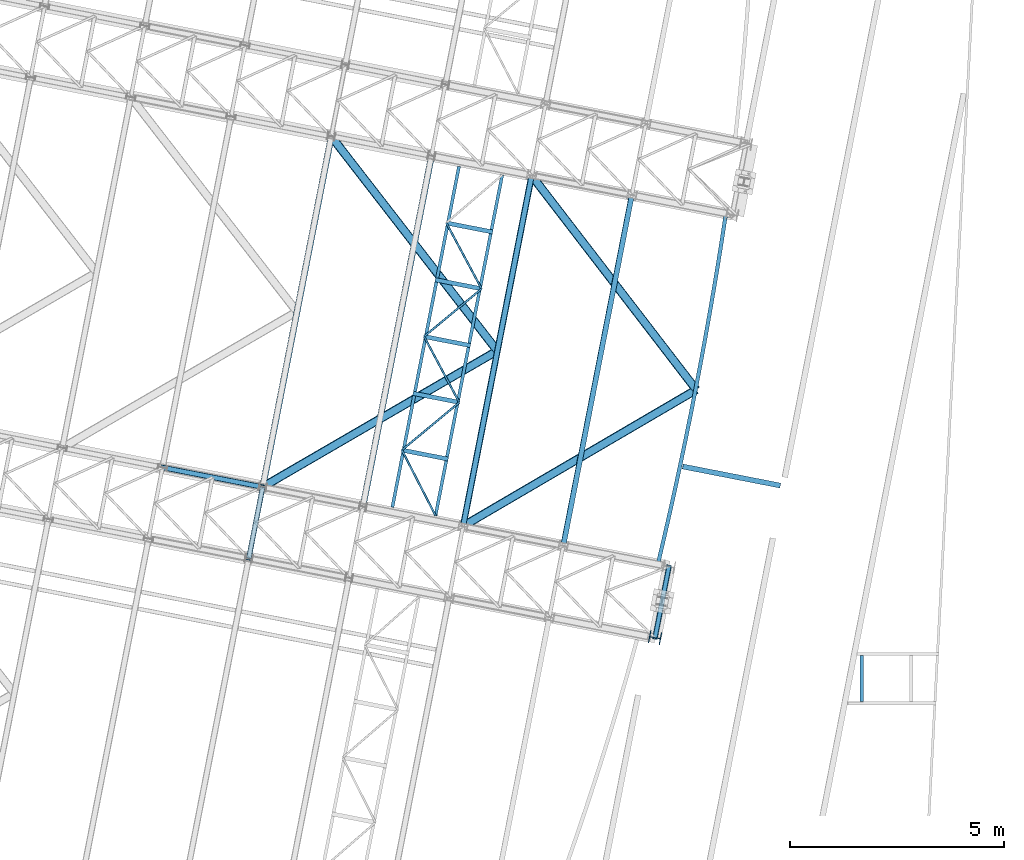
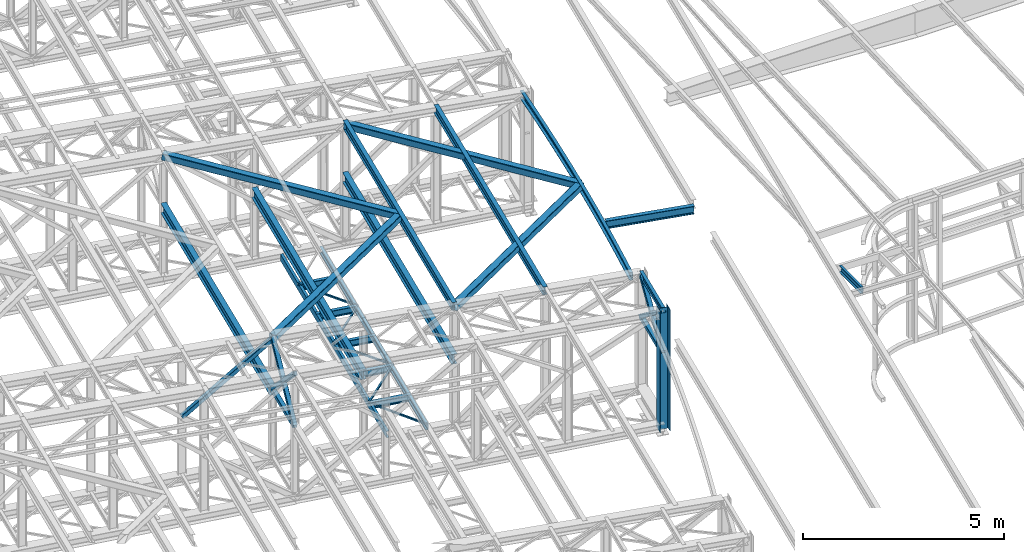
# One storey, part 62 of 215: 28 beams, 5 members, 33 elements without a shape of their own.
"""IFC2X3 building model written with IfcOpenShell, lengths in millimetres."""

from ifc_helpers import new_model, entity, si_unit, frame, origin_with_axes, origin_2d_with_axis, place, context, subcontext, project, spatial, hollow_rectangle, i_section, u_section, extrude, material, type_object, element, aggregate, save


model = new_model("IFC2X3")

# Units and contexts
model_context = context("Model", 3, precision=1e-05, world=origin_with_axes())
body_context = subcontext(model_context, "Body", "Model", "MODEL_VIEW")
ifc_project = project(units=[si_unit("LENGTHUNIT", "METRE", prefix="MILLI"), si_unit("AREAUNIT", "SQUARE_METRE"), si_unit("VOLUMEUNIT", "CUBIC_METRE"), si_unit("MASSUNIT", "GRAM", prefix="KILO"), si_unit("TIMEUNIT", "SECOND"), si_unit("PLANEANGLEUNIT", "RADIAN"), si_unit("SOLIDANGLEUNIT", "STERADIAN"), si_unit("THERMODYNAMICTEMPERATUREUNIT", "DEGREE_CELSIUS"), si_unit("LUMINOUSINTENSITYUNIT", "LUMEN")], contexts=[model_context])

# Site, building, storey
site_placement = place(None, origin_with_axes())
site = spatial("IfcSite", under=ifc_project, at=site_placement, CompositionType="ELEMENT")
building_placement = place(site_placement, origin_with_axes())
building = spatial("IfcBuilding", under=site, at=building_placement, Name="Undefined", CompositionType="ELEMENT")
storey_placement = place(building_placement, origin_with_axes())
storey = spatial("IfcBuildingStorey", under=building, at=storey_placement, Name="Undefined", CompositionType="ELEMENT", Elevation=0.0)

# Assembly, beam
assembly_1_placement = place(storey_placement, origin_with_axes())
assembly_1 = element("IfcElementAssembly", 1, at=assembly_1_placement, inside=storey, Name="Steel Assembly", AssemblyPlace="NOTDEFINED", PredefinedType="RIGID_FRAME")
ifc_material_1 = material(Name="STEEL/S275JR")
beam_type_1 = type_object("IfcBeamType", Name="IPE240", PredefinedType="NOTDEFINED")
beam_1_placement = place(assembly_1_placement, frame((95611.7119283213, 26204.0396014727, 11987.445961115), z_axis=(0.0304080349965938, -0.00594450399933318, 0.999519891888024), x_axis=(-0.980951221876683, 0.191767344975893, 0.0309836359961049)))
beam_1 = element("IfcBeam", 2, at=beam_1_placement, type_object=beam_type_1, material=ifc_material_1, Name="TRAVERSE", ObjectType="IPE240", context=body_context, shape_type="SweptSolid", body=[
    extrude(i_section(OverallWidth=120.0, OverallDepth=240.0, WebThickness=6.199999809, FlangeThickness=9.800000191, FilletRadius=15.0, at=origin_2d_with_axis()), frame((2325.21493417492, -8.17751819121875e-15, 1.81898940354586e-12), z_axis=(-1.0, 0.0, 0.0), x_axis=(-6.93889390390723e-18, -1.0, -3.46944695195361e-18)), (0.0, 0.0, 1.0), 2325.2),
])
aggregate(assembly_1, [beam_1])

assembly_2_placement = place(storey_placement, origin_with_axes())
assembly_2 = element("IfcElementAssembly", 3, at=assembly_2_placement, inside=storey, Name="Steel Assembly", AssemblyPlace="NOTDEFINED", PredefinedType="RIGID_FRAME")
beam_2_placement = place(assembly_2_placement, frame((90534.3986984975, 24794.5320727854, 12133.5283988097), z_axis=(0.0304080349965938, -0.00594450399933318, 0.999519891888024), x_axis=(0.191859470081235, 0.981422408415534, 0.0)))
beam_2 = element("IfcBeam", 4, at=beam_2_placement, type_object=beam_type_1, material=ifc_material_1, ObjectType="IPE240", context=body_context, shape_type="SweptSolid", body=[
    extrude(i_section(OverallWidth=120.0, OverallDepth=240.0, WebThickness=6.199999809, FlangeThickness=9.800000191, FilletRadius=15.0, at=origin_2d_with_axis()), frame((8361.40106173832, 0.0, -1.81898940354586e-12), z_axis=(-1.0, 0.0, 0.0), x_axis=(-6.93889390390723e-18, -1.0, -3.46944695195361e-18)), (0.0, 0.0, 1.0), 8361.4),
])
aggregate(assembly_2, [beam_2])

assembly_3_placement = place(storey_placement, origin_with_axes())
assembly_3 = element("IfcElementAssembly", 5, at=assembly_3_placement, inside=storey, Name="Steel Assembly", AssemblyPlace="NOTDEFINED", PredefinedType="RIGID_FRAME")
beam_3_placement = place(assembly_3_placement, frame((88190.3508185436, 25252.7728198402, 12207.5658566759), z_axis=(0.0304080349965938, -0.00594450399933318, 0.999519891888024), x_axis=(0.191859470081235, 0.981422408415534, 0.0)))
beam_3 = element("IfcBeam", 6, at=beam_3_placement, type_object=beam_type_1, material=ifc_material_1, ObjectType="IPE240", context=body_context, shape_type="SweptSolid", body=[
    extrude(i_section(OverallWidth=120.0, OverallDepth=240.0, WebThickness=6.199999809, FlangeThickness=9.800000191, FilletRadius=15.0, at=origin_2d_with_axis()), frame((8361.40106173832, 0.0, -1.81898940354586e-12), z_axis=(-1.0, 0.0, 0.0), x_axis=(-6.93889390390723e-18, -1.0, -3.46944695195361e-18)), (0.0, 0.0, 1.0), 8361.4),
])
aggregate(assembly_3, [beam_3])

assembly_4_placement = place(storey_placement, origin_with_axes())
assembly_4 = element("IfcElementAssembly", 7, at=assembly_4_placement, inside=storey, Name="Steel Assembly", AssemblyPlace="NOTDEFINED", PredefinedType="RIGID_FRAME")
beam_type_2 = type_object("IfcBeamType", PredefinedType="NOTDEFINED")
beam_4_placement = place(assembly_4_placement, frame((83179.7440072952, 24500.1229085708, 10796.000000583), z_axis=(0.981422364268518, -0.191859461052493, -0.000300197000082615), x_axis=(0.191859470081235, 0.981422408415534, 0.0)))
beam_4 = element("IfcBeam", 8, at=beam_4_placement, type_object=beam_type_2, material=ifc_material_1, context=body_context, shape_type="SweptSolid", body=[
    extrude(hollow_rectangle(XDim=120.0, YDim=120.0, WallThickness=5.0, InnerFilletRadius=5.0, OuterFilletRadius=10.0, at=origin_2d_with_axis()), frame((1699.99999941724, 1.81898940354586e-12, 0.0), z_axis=(-1.0, 0.0, 0.0), x_axis=(-6.93889390390723e-18, -1.0, -3.46944695195361e-18)), (0.0, 0.0, 1.0), 1700.0),
])
aggregate(assembly_4, [beam_4])

assembly_5_placement = place(storey_placement, origin_with_axes())
assembly_5 = element("IfcElementAssembly", 9, at=assembly_5_placement, inside=storey, Name="Steel Assembly", AssemblyPlace="NOTDEFINED", PredefinedType="RIGID_FRAME")
beam_5_placement = place(assembly_5_placement, frame((92683.809179872, 22642.1616168856, 10796.000000531), z_axis=(0.981422364268518, -0.191859461052493, -0.000300197000082615), x_axis=(0.191859470081235, 0.981422408415534, 0.0)))
beam_5 = element("IfcBeam", 10, at=beam_5_placement, type_object=beam_type_2, material=ifc_material_1, context=body_context, shape_type="SweptSolid", body=[
    extrude(hollow_rectangle(XDim=120.0, YDim=120.0, WallThickness=5.0, InnerFilletRadius=5.0, OuterFilletRadius=10.0, at=origin_2d_with_axis()), frame((1699.99999941724, 1.81898940354586e-12, 0.0), z_axis=(-1.0, 0.0, 0.0), x_axis=(-6.93889390390723e-18, -1.0, -3.46944695195361e-18)), (0.0, 0.0, 1.0), 1700.0),
])
aggregate(assembly_5, [beam_5])

assembly_6_placement = place(storey_placement, origin_with_axes())
assembly_6 = element("IfcElementAssembly", 11, at=assembly_6_placement, inside=storey, Name="Steel Assembly", AssemblyPlace="NOTDEFINED", PredefinedType="RIGID_FRAME")
beam_type_3 = type_object("IfcBeamType", PredefinedType="NOTDEFINED")
beam_6_placement = place(assembly_6_placement, frame((86762.0495059061, 27033.45383983, 8705.0), z_axis=(0.0, 0.0, -1.0), x_axis=(0.456694850924831, -0.889623410853574, 0.0)))
beam_6 = element("IfcBeam", 12, at=beam_6_placement, type_object=beam_type_3, material=ifc_material_1, context=body_context, shape_type="SweptSolid", body=[
    extrude(hollow_rectangle(XDim=50.0, YDim=50.0, WallThickness=3.0, InnerFilletRadius=3.0, OuterFilletRadius=6.0, at=origin_2d_with_axis()), frame((1723.23325364547, -9.5658661749846e-14, 1.81898940354586e-12), z_axis=(-1.0, 0.0, 0.0), x_axis=(-6.93889390390723e-18, -1.0, -3.46944695195361e-18)), (0.0, 0.0, 1.0), 1723.2),
])
aggregate(assembly_6, [beam_6])

assembly_7_placement = place(storey_placement, origin_with_axes())
assembly_7 = element("IfcElementAssembly", 13, at=assembly_7_placement, inside=storey, Name="Steel Assembly", AssemblyPlace="NOTDEFINED", PredefinedType="RIGID_FRAME")
beam_7_placement = place(assembly_7_placement, frame((88104.2576399054, 28148.4363728709, 8705.0), z_axis=(0.0, 0.0, -1.0), x_axis=(-0.769213664946795, -0.6389916569558, 0.0)))
beam_7 = element("IfcBeam", 14, at=beam_7_placement, type_object=beam_type_3, material=ifc_material_1, context=body_context, shape_type="SweptSolid", body=[
    extrude(hollow_rectangle(XDim=50.0, YDim=50.0, WallThickness=3.0, InnerFilletRadius=3.0, OuterFilletRadius=6.0, at=origin_2d_with_axis()), frame((1744.90937426883, 0.0, 0.0), z_axis=(-1.0, 0.0, 0.0), x_axis=(-6.93889390390723e-18, -1.0, -3.46944695195361e-18)), (0.0, 0.0, 1.0), 1744.9),
])
aggregate(assembly_7, [beam_7])

assembly_8_placement = place(storey_placement, origin_with_axes())
assembly_8 = element("IfcElementAssembly", 15, at=assembly_8_placement, inside=storey, Name="Steel Assembly", AssemblyPlace="NOTDEFINED", PredefinedType="RIGID_FRAME")
beam_8_placement = place(assembly_8_placement, frame((87281.4423338355, 29690.2948064892, 8705.0), z_axis=(0.0, 0.0, -1.0), x_axis=(0.470806864168292, -0.882236304315357, 0.0)))
beam_8 = element("IfcBeam", 16, at=beam_8_placement, type_object=beam_type_3, material=ifc_material_1, context=body_context, shape_type="SweptSolid", body=[
    extrude(hollow_rectangle(XDim=50.0, YDim=50.0, WallThickness=3.0, InnerFilletRadius=3.0, OuterFilletRadius=6.0, at=origin_2d_with_axis()), frame((1747.67058027227, 9.70152058839141e-14, 0.0), z_axis=(-1.0, 0.0, 0.0), x_axis=(-6.93889390390723e-18, -1.0, -3.46944695195361e-18)), (0.0, 0.0, 1.0), 1747.7),
])
aggregate(assembly_8, [beam_8])

assembly_9_placement = place(storey_placement, origin_with_axes())
assembly_9 = element("IfcElementAssembly", 17, at=assembly_9_placement, inside=storey, Name="Steel Assembly", AssemblyPlace="NOTDEFINED", PredefinedType="RIGID_FRAME")
beam_9_placement = place(assembly_9_placement, frame((88626.0282196414, 30806.6262081033, 8705.0), z_axis=(0.0, 0.0, -1.0), x_axis=(-0.769389798777998, -0.638779568815685, 0.0)))
beam_9 = element("IfcBeam", 18, at=beam_9_placement, type_object=beam_type_3, material=ifc_material_1, context=body_context, shape_type="SweptSolid", body=[
    extrude(hollow_rectangle(XDim=50.0, YDim=50.0, WallThickness=3.0, InnerFilletRadius=3.0, OuterFilletRadius=6.0, at=origin_2d_with_axis()), frame((1747.60035550756, -7.17894630655705e-12, 0.0), z_axis=(-1.0, 0.0, 0.0), x_axis=(-6.93889390390723e-18, -1.0, -3.46944695195361e-18)), (0.0, 0.0, 1.0), 1747.6),
])
aggregate(assembly_9, [beam_9])

assembly_10_placement = place(storey_placement, origin_with_axes())
assembly_10 = element("IfcElementAssembly", 19, at=assembly_10_placement, inside=storey, Name="Steel Assembly", AssemblyPlace="NOTDEFINED", PredefinedType="RIGID_FRAME")
beam_10_placement = place(assembly_10_placement, frame((87800.835161765, 32347.1357731485, 8705.0), z_axis=(0.0, 0.0, -1.0), x_axis=(0.472185876995929, -0.881499005992398, 0.0)))
beam_10 = element("IfcBeam", 20, at=beam_10_placement, type_object=beam_type_3, material=ifc_material_1, context=body_context, shape_type="SweptSolid", body=[
    extrude(hollow_rectangle(XDim=50.0, YDim=50.0, WallThickness=3.0, InnerFilletRadius=3.0, OuterFilletRadius=6.0, at=origin_2d_with_axis()), frame((1747.60215800794, 1.46489266360521e-11, 0.0), z_axis=(-1.0, 0.0, 0.0), x_axis=(-6.93889390390723e-18, -1.0, -3.46944695195361e-18)), (0.0, 0.0, 1.0), 1747.6),
])
aggregate(assembly_10, [beam_10])

assembly_11_placement = place(storey_placement, origin_with_axes())
assembly_11 = element("IfcElementAssembly", 21, at=assembly_11_placement, inside=storey, Name="Steel Assembly", AssemblyPlace="NOTDEFINED", PredefinedType="RIGID_FRAME")
beam_type_4 = type_object("IfcBeamType", Name="IPE180", PredefinedType="NOTDEFINED")
beam_11_placement = place(assembly_11_placement, frame((93009.9714655941, 24310.5796818302, 12088.0104060162), z_axis=(0.0, 0.0, 1.0), x_axis=(-0.191859508000518, -0.981422401002646, -1.00000033853845e-09)))
beam_11 = element("IfcBeam", 22, at=beam_11_placement, type_object=beam_type_4, material=ifc_material_1, ObjectType="IPE180", context=body_context, shape_type="SweptSolid", body=[
    extrude(i_section(OverallWidth=91.0, OverallDepth=180.0, WebThickness=5.300000191, FlangeThickness=8.0, FilletRadius=9.0, at=origin_2d_with_axis()), frame((1699.99999941724, 1.81898940354586e-12, 0.0), z_axis=(-1.0, 0.0, 0.0), x_axis=(-6.93889390390723e-18, -1.0, -3.46944695195361e-18)), (0.0, 0.0, 1.0), 1700.0),
])
aggregate(assembly_11, [beam_11])

assembly_12_placement = place(storey_placement, origin_with_axes())
assembly_12 = element("IfcElementAssembly", 23, at=assembly_12_placement, inside=storey, Name="Steel Assembly", AssemblyPlace="NOTDEFINED", PredefinedType="RIGID_FRAME")
ifc_material_2 = material(Name="STEEL/S235JR")
beam_type_5 = type_object("IfcBeamType", Name="UPN200", PredefinedType="NOTDEFINED")
beam_12_placement = place(assembly_12_placement, frame((97518.3112663461, 22226.862892061, 11925.4802689789), z_axis=(0.0303815210100789, -0.0060801320020156, 0.999519882331488), x_axis=(1.02169999980284e-05, -0.999981496805265, -0.00608325099881581)))
beam_12 = element("IfcBeam", 24, at=beam_12_placement, type_object=beam_type_5, material=ifc_material_2, ObjectType="UPN200", context=body_context, shape_type="SweptSolid", body=[
    extrude(u_section(Depth=200.0, FlangeWidth=75.0, WebThickness=8.5, FlangeThickness=11.5, FilletRadius=11.5, EdgeRadius=6.0, FlangeSlope=0.0798299857122373, at=origin_2d_with_axis()), frame((1079.96358222926, -1.45519152283669e-11, -1.81898940354586e-12), z_axis=(-1.0, 0.0, 0.0), x_axis=(-6.93889390390723e-18, -1.0, -3.46944695195361e-18)), (0.0, 0.0, 1.0), 1080.0),
])
aggregate(assembly_12, [beam_12])

assembly_13_placement = place(storey_placement, origin_with_axes())
assembly_13 = element("IfcElementAssembly", 25, at=assembly_13_placement, inside=storey, Name="Steel Assembly", AssemblyPlace="NOTDEFINED", PredefinedType="RIGID_FRAME")
beam_13_placement = place(assembly_13_placement, frame((88097.3349063175, 33668.3614765905, 8630.00000003358), z_axis=(0.0, 0.0, -1.0), x_axis=(-0.191860814904866, -0.981422145513357, 0.0)))
beam_13 = element("IfcBeam", 26, at=beam_13_placement, type_object=beam_type_5, material=ifc_material_1, ObjectType="UPN200", context=body_context, shape_type="SweptSolid", body=[
    extrude(u_section(Depth=200.0, FlangeWidth=75.0, WebThickness=8.5, FlangeThickness=11.5, FilletRadius=11.5, EdgeRadius=6.0, FlangeSlope=0.0798299857122373, at=origin_2d_with_axis()), frame((8121.40107902624, 0.0, 0.0), z_axis=(-1.0, 0.0, 0.0), x_axis=(-6.93889390390723e-18, -1.0, -3.46944695195361e-18)), (0.0, 0.0, 1.0), 8121.4),
])
aggregate(assembly_13, [beam_13])

assembly_14_placement = place(storey_placement, origin_with_axes())
assembly_14 = element("IfcElementAssembly", 27, at=assembly_14_placement, inside=storey, Name="Steel Assembly", AssemblyPlace="NOTDEFINED", PredefinedType="RIGID_FRAME")
beam_14_placement = place(assembly_14_placement, frame((87549.0412610662, 25500.4251956975, 8630.00000000009), z_axis=(0.0, 0.0, -1.0), x_axis=(0.192120705997516, 0.981371302987313, 0.0)))
beam_14 = element("IfcBeam", 28, at=beam_14_placement, type_object=beam_type_5, material=ifc_material_1, ObjectType="UPN200", context=body_context, shape_type="SweptSolid", body=[
    extrude(u_section(Depth=200.0, FlangeWidth=75.0, WebThickness=8.5, FlangeThickness=11.5, FilletRadius=11.5, EdgeRadius=6.0, FlangeSlope=0.0798299857122373, at=origin_2d_with_axis()), frame((8121.40136668034, -1.41010868888913e-11, -1.81898940354586e-12), z_axis=(-1.0, 0.0, 0.0), x_axis=(-6.93889390390723e-18, -1.0, -3.46944695195361e-18)), (0.0, 0.0, 1.0), 8121.4),
])
aggregate(assembly_14, [beam_14])

# Assembly, member
assembly_15_placement = place(storey_placement, origin_with_axes())
assembly_15 = element("IfcElementAssembly", 29, at=assembly_15_placement, inside=storey, Name="Steel Assembly", AssemblyPlace="NOTDEFINED", PredefinedType="RIGID_FRAME")
member_type = type_object("IfcMemberType", PredefinedType="NOTDEFINED")
member_1_placement = place(assembly_15_placement, frame((83505.9051055492, 26168.5410024137, 10796.0000007861), z_axis=(0.981461701624211, -0.19165823792662, 0.000219270999915979), x_axis=(-0.140138869039808, -0.716855033203644, 0.682993381194025)))
member_1 = element("IfcMember", 30, at=member_1_placement, type_object=member_type, material=ifc_material_1, context=body_context, shape_type="SweptSolid", body=[
    extrude(hollow_rectangle(XDim=120.0, YDim=120.0, WallThickness=5.0, InnerFilletRadius=5.0, OuterFilletRadius=10.0, at=origin_2d_with_axis()), frame((2327.41350452431, -7.27595761418343e-12, -1.06739260704213e-13), z_axis=(-1.0, 0.0, 0.0), x_axis=(-6.93889390390723e-18, -1.0, -3.46944695195361e-18)), (0.0, 0.0, 1.0), 2327.4),
])
aggregate(assembly_15, [member_1])

assembly_16_placement = place(storey_placement, origin_with_axes())
assembly_16 = element("IfcElementAssembly", 31, at=assembly_16_placement, inside=storey, Name="Steel Assembly", AssemblyPlace="NOTDEFINED", PredefinedType="RIGID_FRAME")
member_2_placement = place(assembly_16_placement, frame((83179.7440072952, 24500.1229085708, 10796.000000583), z_axis=(0.981461701624211, -0.19165823792662, -0.000219270999915979), x_axis=(0.140138870001192, 0.716855037006089, 0.682993377005801)))
member_2 = element("IfcMember", 32, at=member_2_placement, type_object=member_type, material=ifc_material_1, context=body_context, shape_type="SweptSolid", body=[
    extrude(hollow_rectangle(XDim=120.0, YDim=120.0, WallThickness=5.0, InnerFilletRadius=5.0, OuterFilletRadius=10.0, at=origin_2d_with_axis()), frame((2327.41350452431, -7.27595761418343e-12, -1.06739260704213e-13), z_axis=(-1.0, 0.0, 0.0), x_axis=(-6.93889390390723e-18, -1.0, -3.46944695195361e-18)), (0.0, 0.0, 1.0), 2327.4),
])
aggregate(assembly_16, [member_2])

assembly_17_placement = place(storey_placement, origin_with_axes())
assembly_17 = element("IfcElementAssembly", 33, at=assembly_17_placement, inside=storey, Name="Steel Assembly", AssemblyPlace="NOTDEFINED", PredefinedType="RIGID_FRAME")
member_3_placement = place(assembly_17_placement, frame((93009.9702784118, 24310.5797106813, 10796.0000008411), z_axis=(0.981457237582708, -0.191681072918501, 0.000238916999899001), x_axis=(-0.152684252020592, -0.781028668105336, 0.605542516081668)))
member_3 = element("IfcMember", 34, at=member_3_placement, type_object=member_type, material=ifc_material_1, context=body_context, shape_type="SweptSolid", body=[
    extrude(hollow_rectangle(XDim=120.0, YDim=120.0, WallThickness=5.0, InnerFilletRadius=5.0, OuterFilletRadius=10.0, at=origin_2d_with_axis()), frame((2136.18034008032, 0.0, 4.6147323458303e-14), z_axis=(-1.0, 0.0, 0.0), x_axis=(-6.93889390390723e-18, -1.0, -3.46944695195361e-18)), (0.0, 0.0, 1.0), 2136.2),
])
aggregate(assembly_17, [member_3])

assembly_18_placement = place(storey_placement, origin_with_axes())
assembly_18 = element("IfcElementAssembly", 35, at=assembly_18_placement, inside=storey, Name="Steel Assembly", AssemblyPlace="NOTDEFINED", PredefinedType="RIGID_FRAME")
member_4_placement = place(assembly_18_placement, frame((92683.809179872, 22642.1616168856, 10796.000000531), z_axis=(0.981457237582473, -0.191681072918455, -0.000238917999897463), x_axis=(0.152684253009357, 0.781028671047852, 0.6055425120371)))
member_4 = element("IfcMember", 36, at=member_4_placement, type_object=member_type, material=ifc_material_1, context=body_context, shape_type="SweptSolid", body=[
    extrude(hollow_rectangle(XDim=120.0, YDim=120.0, WallThickness=5.0, InnerFilletRadius=5.0, OuterFilletRadius=10.0, at=origin_2d_with_axis()), frame((2136.18034008032, 0.0, 4.6147323458303e-14), z_axis=(-1.0, 0.0, 0.0), x_axis=(-6.93889390390723e-18, -1.0, -3.46944695195361e-18)), (0.0, 0.0, 1.0), 2136.2),
])
aggregate(assembly_18, [member_4])

assembly_19_placement = place(storey_placement, origin_with_axes())
assembly_19 = element("IfcElementAssembly", 37, at=assembly_19_placement, inside=storey, Name="Steel Assembly", AssemblyPlace="NOTDEFINED", PredefinedType="RIGID_FRAME")
member_5_placement = place(assembly_19_placement, frame((81161.8564156366, 26626.7819829889, 10489.6726245388), z_axis=(0.597857237183729, -0.116875832035918, -0.793036420243705), x_axis=(0.778303714010845, -0.15215154400212, 0.609174225008491)))
member_5 = element("IfcMember", 38, at=member_5_placement, type_object=member_type, material=ifc_material_1, context=body_context, shape_type="SweptSolid", body=[
    extrude(hollow_rectangle(XDim=120.0, YDim=120.0, WallThickness=5.0, InnerFilletRadius=5.0, OuterFilletRadius=10.0, at=origin_2d_with_axis()), frame((3005.68349365877, -3.45147056449385e-14, 7.44280656515321e-12), z_axis=(-1.0, 0.0, 0.0), x_axis=(-6.93889390390723e-18, -1.0, -3.46944695195361e-18)), (0.0, 0.0, 1.0), 3005.7),
])
aggregate(assembly_19, [member_5])

# Assembly, beam
assembly_20_placement = place(storey_placement, origin_with_axes())
assembly_20 = element("IfcElementAssembly", 39, at=assembly_20_placement, inside=storey, Name="Steel Assembly", AssemblyPlace="NOTDEFINED", PredefinedType="RIGID_FRAME")
beam_type_6 = type_object("IfcBeamType", PredefinedType="NOTDEFINED")
beam_15_placement = place(assembly_20_placement, frame((88992.1105509068, 29356.1250005375, 12194.5963000346), z_axis=(0.0303378029878793, -0.00559570999776539, 0.999524039600594), x_axis=(-0.612030851936216, 0.790499299917617, 0.0230020239976028)))
beam_15 = element("IfcBeam", 40, at=beam_15_placement, type_object=beam_type_6, material=ifc_material_1, context=body_context, shape_type="SweptSolid", body=[
    extrude(hollow_rectangle(XDim=200.0, YDim=200.0, WallThickness=10.0, InnerFilletRadius=15.0, OuterFilletRadius=25.0, at=origin_2d_with_axis()), frame((6349.51246722592, -6.06494074105851e-13, -1.81898940354586e-12), z_axis=(-1.0, 0.0, 0.0), x_axis=(-6.93889390390723e-18, -1.0, -3.46944695195361e-18)), (0.0, 0.0, 1.0), 6349.5),
])
aggregate(assembly_20, [beam_15])

assembly_21_placement = place(storey_placement, origin_with_axes())
assembly_21 = element("IfcElementAssembly", 41, at=assembly_21_placement, inside=storey, Name="Steel Assembly", AssemblyPlace="NOTDEFINED", PredefinedType="RIGID_FRAME")
beam_16_placement = place(assembly_21_placement, frame((88992.0489980518, 29356.1370337303, 12192.5730491124), z_axis=(0.0304080349965938, -0.00594450399933318, 0.999519891888024), x_axis=(-0.864628555736928, -0.501870164847301, 0.0233194819929049)))
beam_16 = element("IfcBeam", 42, at=beam_16_placement, type_object=beam_type_6, material=ifc_material_1, context=body_context, shape_type="SweptSolid", body=[
    extrude(hollow_rectangle(XDim=200.0, YDim=200.0, WallThickness=10.0, InnerFilletRadius=15.0, OuterFilletRadius=25.0, at=origin_2d_with_axis()), frame((6349.83661532856, 5.61049270900543e-12, 1.81898940354586e-12), z_axis=(-1.0, 0.0, 0.0), x_axis=(-6.93889390390723e-18, -1.0, -3.46944695195361e-18)), (0.0, 0.0, 1.0), 6349.8),
])
aggregate(assembly_21, [beam_16])

assembly_22_placement = place(storey_placement, origin_with_axes())
assembly_22 = element("IfcElementAssembly", 43, at=assembly_22_placement, inside=storey, Name="Steel Assembly", AssemblyPlace="NOTDEFINED", PredefinedType="RIGID_FRAME")
beam_17_placement = place(assembly_22_placement, frame((93647.0173800509, 28446.1315219296, 12047.5696827255), z_axis=(0.0303382510020151, -0.00559444800037257, 0.999524033066594), x_axis=(-0.609243542987612, 0.792651611983883, 0.0229287449995338)))
beam_17 = element("IfcBeam", 44, at=beam_17_placement, type_object=beam_type_6, material=ifc_material_1, context=body_context, shape_type="SweptSolid", body=[
    extrude(hollow_rectangle(XDim=200.0, YDim=200.0, WallThickness=10.0, InnerFilletRadius=15.0, OuterFilletRadius=25.0, at=origin_2d_with_axis()), frame((6324.08607517481, -8.57073482711232e-14, 1.84093048470326e-12), z_axis=(-1.0, 0.0, 0.0), x_axis=(-6.93889390390723e-18, -1.0, -3.46944695195361e-18)), (0.0, 0.0, 1.0), 6324.1),
])
aggregate(assembly_22, [beam_17])

assembly_23_placement = place(storey_placement, origin_with_axes())
assembly_23 = element("IfcElementAssembly", 45, at=assembly_23_placement, inside=storey, Name="Steel Assembly", AssemblyPlace="NOTDEFINED", PredefinedType="RIGID_FRAME")
beam_18_placement = place(assembly_23_placement, frame((93646.9558271959, 28446.1435551223, 12045.5464318033), z_axis=(0.0304080349965938, -0.00594450399933318, 0.999519891888024), x_axis=(-0.862856745188956, -0.50491364811057, 0.023247478005091)))
beam_18 = element("IfcBeam", 46, at=beam_18_placement, type_object=beam_type_6, material=ifc_material_1, context=body_context, shape_type="SweptSolid", body=[
    extrude(hollow_rectangle(XDim=200.0, YDim=200.0, WallThickness=10.0, InnerFilletRadius=15.0, OuterFilletRadius=25.0, at=origin_2d_with_axis()), frame((6324.41152630917, 2.46849865794603e-14, -1.81898940354586e-12), z_axis=(-1.0, 0.0, 0.0), x_axis=(-6.93889390390723e-18, -1.0, -3.46944695195361e-18)), (0.0, 0.0, 1.0), 6324.4),
])
aggregate(assembly_23, [beam_18])

assembly_24_placement = place(storey_placement, origin_with_axes())
assembly_24 = element("IfcElementAssembly", 47, at=assembly_24_placement, inside=storey, Name="Steel Assembly", AssemblyPlace="NOTDEFINED", PredefinedType="RIGID_FRAME")
beam_type_7 = type_object("IfcBeamType", Name="IPE300", PredefinedType="NOTDEFINED")
beam_19_placement = place(assembly_24_placement, frame((88194.0042328168, 25252.0589467664, 10605.5499977022), z_axis=(0.0, 0.0, 1.0), x_axis=(0.191859470081235, 0.981422408415534, 0.0)))
beam_19 = element("IfcBeam", 48, at=beam_19_placement, type_object=beam_type_7, material=ifc_material_1, Name="SUPPORT", ObjectType="IPE300", context=body_context, shape_type="SweptSolid", body=[
    extrude(i_section(OverallWidth=150.0, OverallDepth=300.0, WebThickness=7.099999905, FlangeThickness=10.69999981, FilletRadius=15.0, at=origin_2d_with_axis()), frame((8361.40106173832, 0.0, -1.81898940354586e-12), z_axis=(-1.0, 0.0, 0.0), x_axis=(-6.93889390390723e-18, -1.0, -3.46944695195361e-18)), (0.0, 0.0, 1.0), 8361.4),
])
aggregate(assembly_24, [beam_19])

assembly_25_placement = place(storey_placement, origin_with_axes())
assembly_25 = element("IfcElementAssembly", 49, at=assembly_25_placement, inside=storey, Name="Steel Assembly", AssemblyPlace="NOTDEFINED", PredefinedType="RIGID_FRAME")
beam_20_placement = place(assembly_25_placement, frame((85849.9563525451, 25710.2996938185, 10679.5800000712), z_axis=(0.0, 0.0, 1.0), x_axis=(0.191859470081235, 0.981422408415534, 0.0)))
beam_20 = element("IfcBeam", 50, at=beam_20_placement, type_object=beam_type_7, material=ifc_material_1, Name="SUPPORT", ObjectType="IPE300", context=body_context, shape_type="SweptSolid", body=[
    extrude(i_section(OverallWidth=150.0, OverallDepth=300.0, WebThickness=7.099999905, FlangeThickness=10.69999981, FilletRadius=15.0, at=origin_2d_with_axis()), frame((8361.40106173832, 0.0, -1.81898940354586e-12), z_axis=(-1.0, 0.0, 0.0), x_axis=(-6.93889390390723e-18, -1.0, -3.46944695195361e-18)), (0.0, 0.0, 1.0), 8361.4),
])
aggregate(assembly_25, [beam_20])

assembly_26_placement = place(storey_placement, origin_with_axes())
assembly_26 = element("IfcElementAssembly", 51, at=assembly_26_placement, inside=storey, Name="Steel Assembly", AssemblyPlace="NOTDEFINED", PredefinedType="RIGID_FRAME")
beam_21_placement = place(assembly_26_placement, frame((83505.9084719121, 26168.5404407439, 10753.6200000398), z_axis=(0.0, 0.0, 1.0), x_axis=(0.191859470081235, 0.981422408415534, 0.0)))
beam_21 = element("IfcBeam", 52, at=beam_21_placement, type_object=beam_type_7, material=ifc_material_1, Name="SUPPORT", ObjectType="IPE300", context=body_context, shape_type="SweptSolid", body=[
    extrude(i_section(OverallWidth=150.0, OverallDepth=300.0, WebThickness=7.099999905, FlangeThickness=10.69999981, FilletRadius=15.0, at=origin_2d_with_axis()), frame((8361.40106173832, 0.0, -1.81898940354586e-12), z_axis=(-1.0, 0.0, 0.0), x_axis=(-6.93889390390723e-18, -1.0, -3.46944695195361e-18)), (0.0, 0.0, 1.0), 8361.4),
])
aggregate(assembly_26, [beam_21])

assembly_27_placement = place(storey_placement, origin_with_axes())
assembly_27 = element("IfcElementAssembly", 53, at=assembly_27_placement, inside=storey, Name="Steel Assembly", AssemblyPlace="NOTDEFINED", PredefinedType="RIGID_FRAME")
beam_type_8 = type_object("IfcBeamType", Name="IPE200", PredefinedType="NOTDEFINED")
beam_22_placement = place(assembly_27_placement, frame((88886.0745933107, 32134.978180661, 8630.00000000005), z_axis=(0.0, 0.0, -1.0), x_axis=(-0.981421930660668, 0.191861913933662, 0.0)))
beam_22 = element("IfcBeam", 54, at=beam_22_placement, type_object=beam_type_8, material=ifc_material_1, ObjectType="IPE200", context=body_context, shape_type="SweptSolid", body=[
    extrude(i_section(OverallWidth=100.0, OverallDepth=200.0, WebThickness=5.599999905, FlangeThickness=8.5, FilletRadius=12.0, at=origin_2d_with_axis()), frame((1105.78273986562, 0.0, 0.0), z_axis=(-1.0, 0.0, 0.0), x_axis=(-6.93889390390723e-18, -1.0, -3.46944695195361e-18)), (0.0, 0.0, 1.0), 1105.8),
])
aggregate(assembly_27, [beam_22])

assembly_28_placement = place(storey_placement, origin_with_axes())
assembly_28 = element("IfcElementAssembly", 55, at=assembly_28_placement, inside=storey, Name="Steel Assembly", AssemblyPlace="NOTDEFINED", PredefinedType="RIGID_FRAME")
beam_23_placement = place(assembly_28_placement, frame((88626.0282196414, 30806.6262081033, 8630.00000000005), z_axis=(0.0, 0.0, -1.0), x_axis=(-0.981421930660668, 0.191861913933662, 0.0)))
beam_23 = element("IfcBeam", 56, at=beam_23_placement, type_object=beam_type_8, material=ifc_material_1, ObjectType="IPE200", context=body_context, shape_type="SweptSolid", body=[
    extrude(i_section(OverallWidth=100.0, OverallDepth=200.0, WebThickness=5.599999905, FlangeThickness=8.5, FilletRadius=12.0, at=origin_2d_with_axis()), frame((1105.42613714593, 0.0, 0.0), z_axis=(-1.0, 0.0, 0.0), x_axis=(-6.93889390390723e-18, -1.0, -3.46944695195361e-18)), (0.0, 0.0, 1.0), 1105.4),
])
aggregate(assembly_28, [beam_23])

assembly_29_placement = place(storey_placement, origin_with_axes())
assembly_29 = element("IfcElementAssembly", 57, at=assembly_29_placement, inside=storey, Name="Steel Assembly", AssemblyPlace="NOTDEFINED", PredefinedType="RIGID_FRAME")
beam_24_placement = place(assembly_29_placement, frame((88365.9737201737, 29478.2758262121, 8630.00000000005), z_axis=(0.0, 0.0, -1.0), x_axis=(-0.981421930660668, 0.191861913933662, 0.0)))
beam_24 = element("IfcBeam", 58, at=beam_24_placement, type_object=beam_type_8, material=ifc_material_1, ObjectType="IPE200", context=body_context, shape_type="SweptSolid", body=[
    extrude(i_section(OverallWidth=100.0, OverallDepth=200.0, WebThickness=5.599999905, FlangeThickness=8.5, FilletRadius=12.0, at=origin_2d_with_axis()), frame((1105.06125439967, 3.06716112063917e-14, -1.81898940354586e-12), z_axis=(-1.0, 0.0, 0.0), x_axis=(-6.93889390390723e-18, -1.0, -3.46944695195361e-18)), (0.0, 0.0, 1.0), 1105.1),
])
aggregate(assembly_29, [beam_24])

assembly_30_placement = place(storey_placement, origin_with_axes())
assembly_30 = element("IfcElementAssembly", 59, at=assembly_30_placement, inside=storey, Name="Steel Assembly", AssemblyPlace="NOTDEFINED", PredefinedType="RIGID_FRAME")
beam_25_placement = place(assembly_30_placement, frame((88105.9256694926, 28149.9241820606, 8630.00000000005), z_axis=(0.0, 0.0, -1.0), x_axis=(-0.981422136295317, 0.191860862057732, 0.0)))
beam_25 = element("IfcBeam", 60, at=beam_25_placement, type_object=beam_type_8, material=ifc_material_1, ObjectType="IPE200", context=body_context, shape_type="SweptSolid", body=[
    extrude(i_section(OverallWidth=100.0, OverallDepth=200.0, WebThickness=5.599999905, FlangeThickness=8.5, FilletRadius=12.0, at=origin_2d_with_axis()), frame((1104.70294277565, 0.0, 0.0), z_axis=(-1.0, 0.0, 0.0), x_axis=(-6.93889390390723e-18, -1.0, -3.46944695195361e-18)), (0.0, 0.0, 1.0), 1104.7),
])
aggregate(assembly_30, [beam_25])

assembly_31_placement = place(storey_placement, origin_with_axes())
assembly_31 = element("IfcElementAssembly", 61, at=assembly_31_placement, inside=storey, Name="Steel Assembly", AssemblyPlace="NOTDEFINED", PredefinedType="RIGID_FRAME")
beam_26_placement = place(assembly_31_placement, frame((87845.8774604517, 26821.5725688092, 8630.00000000005), z_axis=(0.0, 0.0, -1.0), x_axis=(-0.981422136295317, 0.191860862057732, 0.0)))
beam_26 = element("IfcBeam", 62, at=beam_26_placement, type_object=beam_type_8, material=ifc_material_1, ObjectType="IPE200", context=body_context, shape_type="SweptSolid", body=[
    extrude(i_section(OverallWidth=100.0, OverallDepth=200.0, WebThickness=5.599999905, FlangeThickness=8.5, FilletRadius=12.0, at=origin_2d_with_axis()), frame((1104.34446982931, 0.0, 0.0), z_axis=(-1.0, 0.0, 0.0), x_axis=(-6.93889390390723e-18, -1.0, -3.46944695195361e-18)), (0.0, 0.0, 1.0), 1104.3),
])
aggregate(assembly_31, [beam_26])

assembly_32_placement = place(storey_placement, origin_with_axes())
assembly_32 = element("IfcElementAssembly", 63, at=assembly_32_placement, inside=storey, Name="Steel Assembly", AssemblyPlace="NOTDEFINED", PredefinedType="RIGID_FRAME")
beam_type_9 = type_object("IfcBeamType", Name="UPE240", PredefinedType="NOTDEFINED")
beam_27_placement = place(assembly_32_placement, frame((92750.0434924746, 24363.2497192502, 12058.0104226991), z_axis=(0.0, 0.0, -1.0), x_axis=(0.190569428054609, 0.981673720281306, -9.99999936147847e-10)))
beam_27 = element("IfcBeam", 64, at=beam_27_placement, type_object=beam_type_9, material=ifc_material_1, ObjectType="UPE240", context=body_context, shape_type="SweptSolid", body=[
    entity("IfcRevolvedAreaSolid", entity("IfcUShapeProfileDef", "AREA", None, entity("IfcAxis2Placement2D", entity("IfcCartesianPoint", [0.0, 0.0]), entity("IfcDirection", [1.0, 0.0])), 240.0, 90.0, 7.0, 12.5, 15.0), entity("IfcAxis2Placement3D", entity("IfcCartesianPoint", [8357.64566254393, 2.30378553964085e-13, 0.0]), entity("IfcDirection", [-0.999125703444053, 0.0418070414813863, -1.08068669317509e-27]), entity("IfcDirection", [-0.0418070414813863, -0.999125703444053, 2.58267941060102e-26])), entity("IfcAxis1Placement", entity("IfcCartesianPoint", [99955.0, 0.0, 0.0]), entity("IfcDirection", [0.0, 1.0, 0.0])), 0.0836384593227735),
])
aggregate(assembly_32, [beam_27])

assembly_33_placement = place(storey_placement, origin_with_axes())
assembly_33 = element("IfcElementAssembly", 65, at=assembly_33_placement, inside=storey, Name="Steel Assembly", AssemblyPlace="NOTDEFINED", PredefinedType="RIGID_FRAME")
beam_type_10 = type_object("IfcBeamType", Name="HEA280", PredefinedType="NOTDEFINED")
beam_28_placement = place(assembly_33_placement, frame((92683.8105406623, 22642.1623010164, 12178.0104060162), z_axis=(0.981422409205525, -0.19185946604018, 1.89999991602007e-08), x_axis=(0.0, 0.0, -1.0)))
beam_28 = element("IfcBeam", 66, at=beam_28_placement, type_object=beam_type_10, material=ifc_material_1, Name="MONTANT", ObjectType="HEA280", context=body_context, shape_type="SweptSolid", body=[
    extrude(i_section(OverallWidth=280.0, OverallDepth=270.0, WebThickness=8.0, FlangeThickness=13.0, FilletRadius=24.0, at=origin_2d_with_axis()), frame((3678.01040601614, 0.0, 0.0), z_axis=(-1.0, 0.0, 0.0), x_axis=(-6.93889390390723e-18, -1.0, -3.46944695195361e-18)), (0.0, 0.0, 1.0), 3678.0),
])
aggregate(assembly_33, [beam_28])

save(model, "model.ifc")
